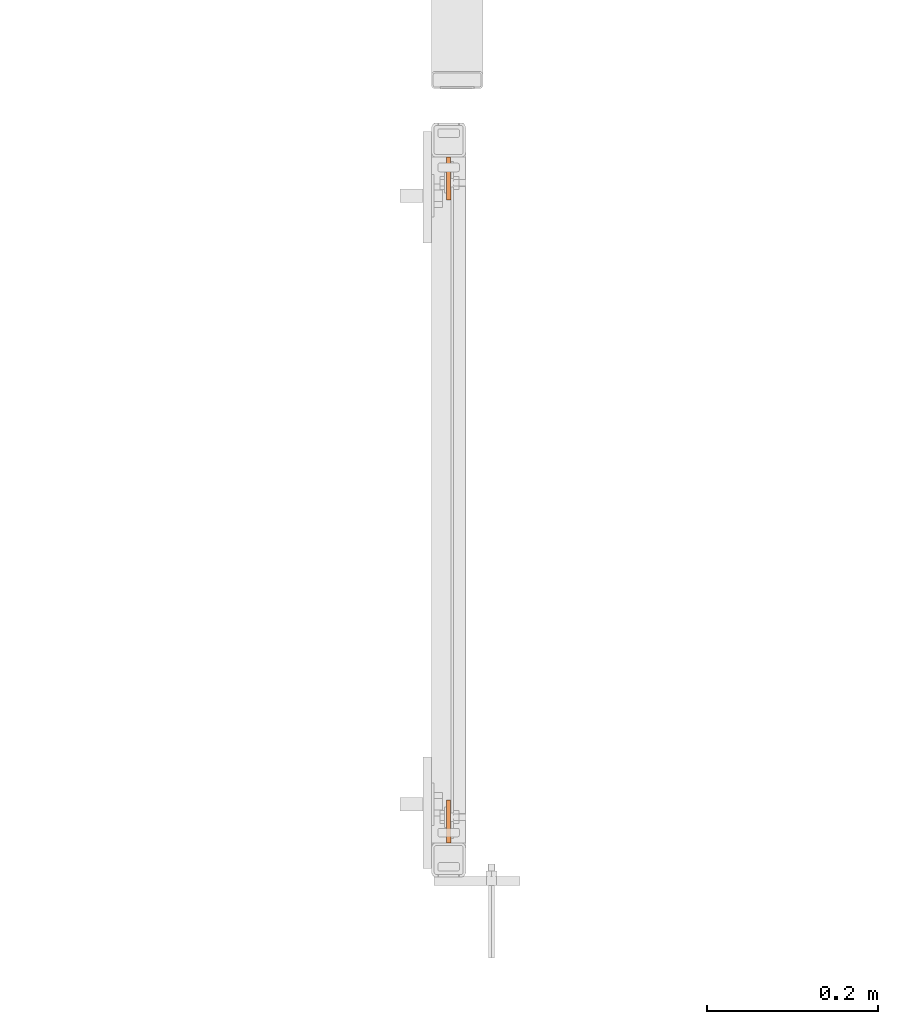
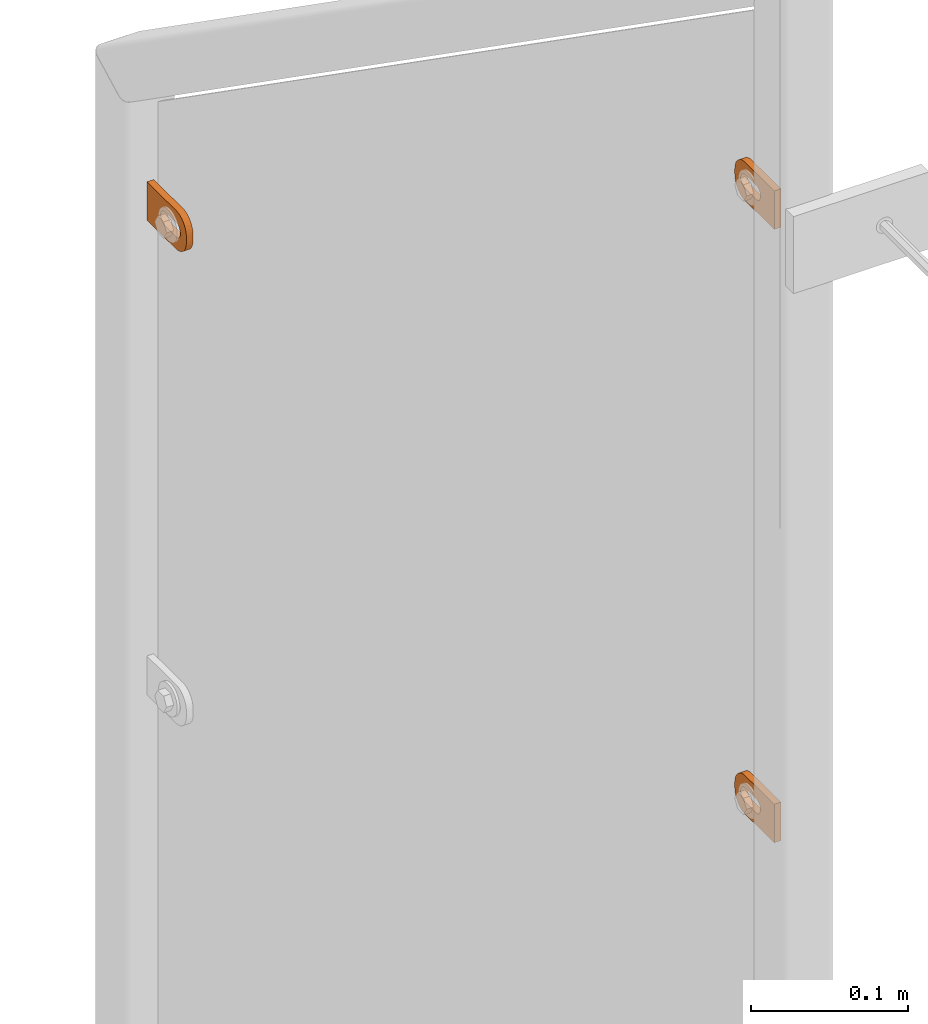
# One storey, part 139 of 156: 3 proxies, 1 element without a shape of its own.
"""IFC2X3 building model written with IfcOpenShell, lengths in millimetres."""

from ifc_helpers import new_model, si_unit, frame, origin_with_axes, place, context, subcontext, project, spatial, faceted_brep, material, type_object, element, aggregate, save


model = new_model("IFC2X3")

# Units and contexts
model_context = context("Model", 3, precision=1e-05, world=origin_with_axes())
body_context = subcontext(model_context, "Body", "Model", "MODEL_VIEW")
ifc_project = project(units=[si_unit("LENGTHUNIT", "METRE", prefix="MILLI"), si_unit("AREAUNIT", "SQUARE_METRE"), si_unit("VOLUMEUNIT", "CUBIC_METRE"), si_unit("MASSUNIT", "GRAM", prefix="KILO"), si_unit("TIMEUNIT", "SECOND"), si_unit("PLANEANGLEUNIT", "RADIAN"), si_unit("SOLIDANGLEUNIT", "STERADIAN"), si_unit("THERMODYNAMICTEMPERATUREUNIT", "DEGREE_CELSIUS"), si_unit("LUMINOUSINTENSITYUNIT", "LUMEN")], contexts=[model_context])

# Site, building, storey
site_placement = place(None, origin_with_axes())
site = spatial("IfcSite", under=ifc_project, at=site_placement, CompositionType="ELEMENT")
building_placement = place(site_placement, origin_with_axes())
building = spatial("IfcBuilding", under=site, at=building_placement, Name="Undefined", CompositionType="ELEMENT")
storey_placement = place(building_placement, origin_with_axes())
storey = spatial("IfcBuildingStorey", under=building, at=storey_placement, Name="Undefined", CompositionType="ELEMENT", Elevation=0.0)

# Assembly, proxies
assembly_placement = place(storey_placement, origin_with_axes())
assembly = element("IfcElementAssembly", 1, at=assembly_placement, inside=storey, AssemblyPlace="NOTDEFINED", PredefinedType="RIGID_FRAME")
ifc_material = material(Name="STEEL/S235JR")
building_element_proxy_type = type_object("IfcBuildingElementProxyType", Name="50", PredefinedType="NOTDEFINED")
proxy_1_placement = place(assembly_placement, frame((26914.9961242676, 22558.0099050151, 5289.31155036594), z_axis=(0.999985556002151, 0.00537473600001249, 0.0), x_axis=(-0.00537473600001187, 0.999985556002151, 1.19999999540802e-08)))
proxy_1 = element("IfcBuildingElementProxy", 2, at=proxy_1_placement, type_object=building_element_proxy_type, material=ifc_material, ObjectType="50", CompositionType="ELEMENT", context=body_context, shape_type="Brep", body=[
    faceted_brep([(37.0000004768226, -5.50000056624776, -2.49999994410609), (23.0000000446889, -5.50000056624594, -2.49999994410973), (23.0000000446889, -5.50000056624594, 2.49999994413156), (37.000000476819, -5.50000056624776, 2.49999994413338), (21.9270028173814, -5.39431966841403, -2.49999994410973), (21.9270028173778, -5.39431966841403, 2.49999994412792), (20.895240828384, -5.0813375413436, -2.49999994411155), (20.895240828384, -5.0813375413436, 2.49999994412974), (19.9443642049955, -4.5730831474084, -2.49999994410973), (19.9443642049919, -4.5730831474084, 2.49999994412792), (19.1109124571012, -3.88908818364325, -2.49999994411155), (19.1109124571012, -3.88908818364325, 2.49999994412792), (18.4269174933361, -3.05563643574806, -2.49999994411155), (18.4269174933361, -3.05563643574806, 2.4999999441261), (17.9186630994009, -2.1047579497108, -2.49999994411155), (17.9186630994009, -2.1047579497108, 2.49999994412428), (17.6056809723377, -1.07299596071425, -2.49999994411337), (17.6056809723341, -1.07299596071425, 2.4999999441261), (17.5000000745022, 3.3527521736687e-07, -2.49999994411519), (17.5000000745058, 3.3527521736687e-07, 2.49999994412428), (17.6056809723377, 1.07299663126287, -2.49999994411701), (17.6056809723377, 1.07299663126287, 2.49999994412428), (17.9186630994154, 2.10475862026124, -2.49999994411701), (17.9186630994118, 2.10475862026124, 2.49999994412246), (18.426917493347, 3.05563617497592, -2.49999994411701), (18.426917493347, 3.05563617497592, 2.49999994412246), (19.1109124571158, 3.88908699154672, -2.49999994411883), (19.1109124571121, 3.88908699154672, 2.49999994412065), (19.9443642050101, 4.57308288663444, -2.49999994411701), (19.9443642050064, 4.57308288663444, 2.49999994412065), (20.8952408283985, 5.08133728056964, -2.49999994411883), (20.8952408283985, 5.08133728056964, 2.49999994412065), (21.9270028173996, 5.39431940764007, -2.49999994411883), (21.927002817396, 5.39431940764007, 2.49999994412065), (23.0000000447108, 5.50000030547199, -2.49999994411883), (23.0000000447071, 5.50000030547199, 2.49999994412246), (37.0000004768408, 5.50000030547017, -2.49999994411519), (37.0000004768408, 5.50000030547017, 2.49999994412428), (38.0729958415031, 5.39431940763825, -2.49999994411519), (38.0729958414995, 5.39431940763825, 2.49999994412428), (39.1047596931458, 5.08133728056691, -2.49999994411337), (39.1047596931421, 5.08133728056691, 2.49999994412428), (40.0556363165415, 4.57308288663171, -2.49999994411519), (40.0556363165379, 4.57308288663171, 2.4999999441261), (40.8890880644285, 3.8890869915449, -2.49999994411337), (40.8890880644285, 3.8890869915449, 2.49999994412792), (41.5730811655449, 3.05563617497228, -2.49999994411337), (41.5730811655449, 3.05563617497228, 2.4999999441261), (42.0813374221252, 2.1047586202576, -2.49999994411155), (42.0813374221252, 2.1047586202576, 2.49999994412792), (42.3943176865469, 1.07299663126014, -2.49999994410973), (42.3943176865469, 1.07299663126014, 2.49999994412974), (42.5000004470239, 3.35271579388063e-07, -2.49999994410973), (42.5000004470276, 3.35271579388063e-07, 2.49999994412974), (42.3943176865469, -1.07299596071698, -2.49999994410791), (42.3943176865432, -1.07299596071698, 2.49999994413156), (42.0813374221179, -2.10475794971444, -2.49999994410791), (42.0813374221143, -2.10475794971444, 2.49999994413338), (41.5730811655376, -3.05563643575169, -2.49999994410791), (41.5730811655339, -3.05563643575169, 2.49999994413156), (40.8890880644176, -3.88908818364507, -2.49999994410609), (40.889088064414, -3.88908818364507, 2.49999994413338), (40.0556363165233, -4.57308314741113, -2.49999994410791), (40.0556363165233, -4.57308314741113, 2.49999994413338), (39.1047596931276, -5.08133754134633, -2.49999994410609), (39.1047596931276, -5.08133754134633, 2.49999994413338), (38.072995841485, -5.39431966841585, -2.49999994410609), (38.072995841485, -5.39431966841585, 2.49999994413156), (37.0000004768044, -14.9999993294514, 2.49999994414065), (39.5361743867034, -14.7502093017147, 2.49999994414065), (41.9748835265273, -14.0104337036646, 2.49999994414065), (44.222414493528, -12.8091058135078, 2.49999994414247), (46.192388981548, -11.1923875659759, 2.49999994413884), (47.809105366443, -9.22241307795593, 2.49999994413884), (49.010433256597, -6.97488397360394, 2.49999994413702), (49.7502088546535, -4.53617483378002, 2.49999994413338), (50.0000007450435, -2.00000092387745, 2.49999994413338), (50.0000007450471, 1.99999973177364, 2.49999994412974), (49.7502088546717, 4.53617457299879, 2.4999999441261), (49.0104332566261, 6.97488464414528, 2.4999999441261), (47.8091053664721, 9.2224128171747, 2.49999994412428), (46.192388981588, 11.1923882365172, 2.49999994412065), (44.2224144935717, 12.8091048542365, 2.49999994411883), (41.9748835265782, 14.0104339085483, 2.49999994411883), (39.5361743867543, 14.7502086334816, 2.49999994411701), (37.0000004768553, 14.9999999999964, 2.49999994411519), (2.91038304567337e-11, 15.0000000000009, 2.49999994410791), (-2.18278728425503e-11, -14.9999993294468, 2.49999994413338), (3.27418092638254e-11, 15.0000000000009, -2.49999994413156), (-2.18278728425503e-11, -14.9999993294468, -2.49999994410791), (37.0000004768008, -14.9999993294514, -2.49999994409882), (39.5361743867034, -14.7502093017147, -2.49999994409882), (41.9748835265309, -14.0104337036646, -2.499999944097), (44.222414493528, -12.8091058135078, -2.49999994409882), (46.1923889815516, -11.1923875659759, -2.49999994409882), (47.8091053664393, -9.22241307795593, -2.49999994410064), (49.0104332566007, -6.97488397360394, -2.49999994410246), (49.7502088546535, -4.53617483378002, -2.49999994410609), (50.0000007450435, -2.00000092387745, -2.49999994410609), (50.0000007450508, 1.99999973177364, -2.49999994410973), (49.750208854668, 4.53617457299879, -2.49999994411155), (49.0104332566261, 6.97488464414528, -2.49999994411337), (47.8091053664721, 9.2224128171747, -2.49999994411519), (46.1923889815916, 11.1923882365172, -2.49999994411883), (44.2224144935717, 12.8091048542365, -2.49999994411883), (41.9748835265782, 14.0104339085483, -2.49999994412065), (39.5361743867579, 14.7502086334816, -2.49999994412246), (37.000000476859, 14.9999999999964, -2.49999994412428)], [[[0, 1, 2, 3]], [[1, 4, 5, 2]], [[4, 6, 7, 5]], [[6, 8, 9, 7]], [[8, 10, 11, 9]], [[10, 12, 13, 11]], [[12, 14, 15, 13]], [[14, 16, 17, 15]], [[16, 18, 19, 17]], [[18, 20, 21, 19]], [[20, 22, 23, 21]], [[22, 24, 25, 23]], [[24, 26, 27, 25]], [[26, 28, 29, 27]], [[28, 30, 31, 29]], [[30, 32, 33, 31]], [[32, 34, 35, 33]], [[34, 36, 37, 35]], [[36, 38, 39, 37]], [[38, 40, 41, 39]], [[40, 42, 43, 41]], [[42, 44, 45, 43]], [[44, 46, 47, 45]], [[46, 48, 49, 47]], [[48, 50, 51, 49]], [[50, 52, 53, 51]], [[52, 54, 55, 53]], [[54, 56, 57, 55]], [[56, 58, 59, 57]], [[58, 60, 61, 59]], [[60, 62, 63, 61]], [[62, 64, 65, 63]], [[64, 66, 67, 65]], [[66, 0, 3, 67]], [[68, 69, 70, 71, 72, 73, 74, 75, 76, 77, 78, 79, 80, 81, 82, 83, 84, 85, 86, 87], [5, 7, 9, 11, 13, 15, 17, 19, 21, 23, 25, 27, 29, 31, 33, 35, 37, 39, 41, 43, 45, 47, 49, 51, 53, 55, 57, 59, 61, 63, 65, 67, 3, 2]], [[86, 88, 89, 87]], [[87, 89, 90, 68]], [[68, 90, 91, 69]], [[69, 91, 92, 70]], [[70, 92, 93, 71]], [[71, 93, 94, 72]], [[72, 94, 95, 73]], [[73, 95, 96, 74]], [[74, 96, 97, 75]], [[75, 97, 98, 76]], [[76, 98, 99, 77]], [[77, 99, 100, 78]], [[78, 100, 101, 79]], [[79, 101, 102, 80]], [[80, 102, 103, 81]], [[81, 103, 104, 82]], [[82, 104, 105, 83]], [[83, 105, 106, 84]], [[84, 106, 107, 85]], [[85, 107, 88, 86]], [[105, 104, 103, 102, 101, 100, 99, 98, 97, 96, 95, 94, 93, 92, 91, 90, 89, 88, 107, 106], [60, 58, 56, 54, 52, 50, 48, 46, 44, 42, 40, 38, 36, 34, 32, 30, 28, 26, 24, 22, 20, 18, 16, 14, 12, 10, 8, 6, 4, 1, 0, 66, 64, 62]]]),
])
proxy_2_placement = place(assembly_placement, frame((26914.7461242676, 23358.0462491401, 4811.41994708695), z_axis=(-0.999985556002151, -0.00537473600001249, 0.0), x_axis=(0.00537473600001187, -0.999985556002151, 1.19999999540802e-08)))
proxy_2 = element("IfcBuildingElementProxy", 3, at=proxy_2_placement, type_object=building_element_proxy_type, material=ifc_material, ObjectType="50", CompositionType="ELEMENT", context=body_context, shape_type="Brep", body=[
    faceted_brep([(37.0000004768226, -5.50000056624776, -2.49999994410609), (23.0000000446889, -5.50000056624594, -2.49999994410973), (23.0000000446889, -5.50000056624594, 2.49999994413156), (37.000000476819, -5.50000056624776, 2.49999994413338), (21.9270028173814, -5.39431966841403, -2.49999994410973), (21.9270028173778, -5.39431966841403, 2.49999994412792), (20.895240828384, -5.0813375413436, -2.49999994411155), (20.895240828384, -5.0813375413436, 2.49999994412974), (19.9443642049955, -4.5730831474084, -2.49999994410973), (19.9443642049919, -4.5730831474084, 2.49999994412792), (19.1109124571012, -3.88908818364325, -2.49999994411155), (19.1109124571012, -3.88908818364325, 2.49999994412792), (18.4269174933361, -3.05563643574806, -2.49999994411155), (18.4269174933361, -3.05563643574806, 2.4999999441261), (17.9186630994009, -2.1047579497108, -2.49999994411155), (17.9186630994009, -2.1047579497108, 2.49999994412428), (17.6056809723377, -1.07299596071425, -2.49999994411337), (17.6056809723341, -1.07299596071425, 2.4999999441261), (17.5000000745022, 3.3527521736687e-07, -2.49999994411519), (17.5000000745058, 3.3527521736687e-07, 2.49999994412428), (17.6056809723377, 1.07299663126287, -2.49999994411701), (17.6056809723377, 1.07299663126287, 2.49999994412428), (17.9186630994154, 2.10475862026124, -2.49999994411701), (17.9186630994118, 2.10475862026124, 2.49999994412246), (18.426917493347, 3.05563617497592, -2.49999994411701), (18.426917493347, 3.05563617497592, 2.49999994412246), (19.1109124571158, 3.88908699154672, -2.49999994411883), (19.1109124571121, 3.88908699154672, 2.49999994412065), (19.9443642050101, 4.57308288663444, -2.49999994411701), (19.9443642050064, 4.57308288663444, 2.49999994412065), (20.8952408283985, 5.08133728056964, -2.49999994411883), (20.8952408283985, 5.08133728056964, 2.49999994412065), (21.9270028173996, 5.39431940764007, -2.49999994411883), (21.927002817396, 5.39431940764007, 2.49999994412065), (23.0000000447108, 5.50000030547199, -2.49999994411883), (23.0000000447071, 5.50000030547199, 2.49999994412246), (37.0000004768408, 5.50000030547017, -2.49999994411519), (37.0000004768408, 5.50000030547017, 2.49999994412428), (38.0729958415031, 5.39431940763825, -2.49999994411519), (38.0729958414995, 5.39431940763825, 2.49999994412428), (39.1047596931458, 5.08133728056691, -2.49999994411337), (39.1047596931421, 5.08133728056691, 2.49999994412428), (40.0556363165415, 4.57308288663171, -2.49999994411519), (40.0556363165379, 4.57308288663171, 2.4999999441261), (40.8890880644285, 3.8890869915449, -2.49999994411337), (40.8890880644285, 3.8890869915449, 2.49999994412792), (41.5730811655449, 3.05563617497228, -2.49999994411337), (41.5730811655449, 3.05563617497228, 2.4999999441261), (42.0813374221252, 2.1047586202576, -2.49999994411155), (42.0813374221252, 2.1047586202576, 2.49999994412792), (42.3943176865469, 1.07299663126014, -2.49999994410973), (42.3943176865469, 1.07299663126014, 2.49999994412974), (42.5000004470239, 3.35271579388063e-07, -2.49999994410973), (42.5000004470276, 3.35271579388063e-07, 2.49999994412974), (42.3943176865469, -1.07299596071698, -2.49999994410791), (42.3943176865432, -1.07299596071698, 2.49999994413156), (42.0813374221179, -2.10475794971444, -2.49999994410791), (42.0813374221143, -2.10475794971444, 2.49999994413338), (41.5730811655376, -3.05563643575169, -2.49999994410791), (41.5730811655339, -3.05563643575169, 2.49999994413156), (40.8890880644176, -3.88908818364507, -2.49999994410609), (40.889088064414, -3.88908818364507, 2.49999994413338), (40.0556363165233, -4.57308314741113, -2.49999994410791), (40.0556363165233, -4.57308314741113, 2.49999994413338), (39.1047596931276, -5.08133754134633, -2.49999994410609), (39.1047596931276, -5.08133754134633, 2.49999994413338), (38.072995841485, -5.39431966841585, -2.49999994410609), (38.072995841485, -5.39431966841585, 2.49999994413156), (37.0000004768044, -14.9999993294514, 2.49999994414065), (39.5361743867034, -14.7502093017147, 2.49999994414065), (41.9748835265273, -14.0104337036646, 2.49999994414065), (44.222414493528, -12.8091058135078, 2.49999994414247), (46.192388981548, -11.1923875659759, 2.49999994413884), (47.809105366443, -9.22241307795593, 2.49999994413884), (49.010433256597, -6.97488397360394, 2.49999994413702), (49.7502088546535, -4.53617483378002, 2.49999994413338), (50.0000007450435, -2.00000092387745, 2.49999994413338), (50.0000007450471, 1.99999973177364, 2.49999994412974), (49.7502088546717, 4.53617457299879, 2.4999999441261), (49.0104332566261, 6.97488464414528, 2.4999999441261), (47.8091053664721, 9.2224128171747, 2.49999994412428), (46.192388981588, 11.1923882365172, 2.49999994412065), (44.2224144935717, 12.8091048542365, 2.49999994411883), (41.9748835265782, 14.0104339085483, 2.49999994411883), (39.5361743867543, 14.7502086334816, 2.49999994411701), (37.0000004768553, 14.9999999999964, 2.49999994411519), (2.91038304567337e-11, 15.0000000000009, 2.49999994410791), (-2.18278728425503e-11, -14.9999993294468, 2.49999994413338), (3.27418092638254e-11, 15.0000000000009, -2.49999994413156), (-2.18278728425503e-11, -14.9999993294468, -2.49999994410791), (37.0000004768008, -14.9999993294514, -2.49999994409882), (39.5361743867034, -14.7502093017147, -2.49999994409882), (41.9748835265309, -14.0104337036646, -2.499999944097), (44.222414493528, -12.8091058135078, -2.49999994409882), (46.1923889815516, -11.1923875659759, -2.49999994409882), (47.8091053664393, -9.22241307795593, -2.49999994410064), (49.0104332566007, -6.97488397360394, -2.49999994410246), (49.7502088546535, -4.53617483378002, -2.49999994410609), (50.0000007450435, -2.00000092387745, -2.49999994410609), (50.0000007450508, 1.99999973177364, -2.49999994410973), (49.750208854668, 4.53617457299879, -2.49999994411155), (49.0104332566261, 6.97488464414528, -2.49999994411337), (47.8091053664721, 9.2224128171747, -2.49999994411519), (46.1923889815916, 11.1923882365172, -2.49999994411883), (44.2224144935717, 12.8091048542365, -2.49999994411883), (41.9748835265782, 14.0104339085483, -2.49999994412065), (39.5361743867579, 14.7502086334816, -2.49999994412246), (37.000000476859, 14.9999999999964, -2.49999994412428)], [[[0, 1, 2, 3]], [[1, 4, 5, 2]], [[4, 6, 7, 5]], [[6, 8, 9, 7]], [[8, 10, 11, 9]], [[10, 12, 13, 11]], [[12, 14, 15, 13]], [[14, 16, 17, 15]], [[16, 18, 19, 17]], [[18, 20, 21, 19]], [[20, 22, 23, 21]], [[22, 24, 25, 23]], [[24, 26, 27, 25]], [[26, 28, 29, 27]], [[28, 30, 31, 29]], [[30, 32, 33, 31]], [[32, 34, 35, 33]], [[34, 36, 37, 35]], [[36, 38, 39, 37]], [[38, 40, 41, 39]], [[40, 42, 43, 41]], [[42, 44, 45, 43]], [[44, 46, 47, 45]], [[46, 48, 49, 47]], [[48, 50, 51, 49]], [[50, 52, 53, 51]], [[52, 54, 55, 53]], [[54, 56, 57, 55]], [[56, 58, 59, 57]], [[58, 60, 61, 59]], [[60, 62, 63, 61]], [[62, 64, 65, 63]], [[64, 66, 67, 65]], [[66, 0, 3, 67]], [[68, 69, 70, 71, 72, 73, 74, 75, 76, 77, 78, 79, 80, 81, 82, 83, 84, 85, 86, 87], [5, 7, 9, 11, 13, 15, 17, 19, 21, 23, 25, 27, 29, 31, 33, 35, 37, 39, 41, 43, 45, 47, 49, 51, 53, 55, 57, 59, 61, 63, 65, 67, 3, 2]], [[86, 88, 89, 87]], [[87, 89, 90, 68]], [[68, 90, 91, 69]], [[69, 91, 92, 70]], [[70, 92, 93, 71]], [[71, 93, 94, 72]], [[72, 94, 95, 73]], [[73, 95, 96, 74]], [[74, 96, 97, 75]], [[75, 97, 98, 76]], [[76, 98, 99, 77]], [[77, 99, 100, 78]], [[78, 100, 101, 79]], [[79, 101, 102, 80]], [[80, 102, 103, 81]], [[81, 103, 104, 82]], [[82, 104, 105, 83]], [[83, 105, 106, 84]], [[84, 106, 107, 85]], [[85, 107, 88, 86]], [[105, 104, 103, 102, 101, 100, 99, 98, 97, 96, 95, 94, 93, 92, 91, 90, 89, 88, 107, 106], [60, 58, 56, 54, 52, 50, 48, 46, 44, 42, 40, 38, 36, 34, 32, 30, 28, 26, 24, 22, 20, 18, 16, 14, 12, 10, 8, 6, 4, 1, 0, 66, 64, 62]]]),
])
proxy_3_placement = place(assembly_placement, frame((26914.9961242676, 22558.0453699462, 4811.62928193643), z_axis=(0.999985556002151, 0.00537473600001249, 0.0), x_axis=(-0.00537473600001187, 0.999985556002151, 1.19999999540802e-08)))
proxy_3 = element("IfcBuildingElementProxy", 4, at=proxy_3_placement, type_object=building_element_proxy_type, material=ifc_material, ObjectType="50", CompositionType="ELEMENT", context=body_context, shape_type="Brep", body=[
    faceted_brep([(37.0000004768226, -5.50000056624776, -2.49999994410609), (23.0000000446889, -5.50000056624594, -2.49999994410973), (23.0000000446889, -5.50000056624594, 2.49999994413156), (37.000000476819, -5.50000056624776, 2.49999994413338), (21.9270028173814, -5.39431966841403, -2.49999994410973), (21.9270028173778, -5.39431966841403, 2.49999994412792), (20.895240828384, -5.0813375413436, -2.49999994411155), (20.895240828384, -5.0813375413436, 2.49999994412974), (19.9443642049955, -4.5730831474084, -2.49999994410973), (19.9443642049919, -4.5730831474084, 2.49999994412792), (19.1109124571012, -3.88908818364325, -2.49999994411155), (19.1109124571012, -3.88908818364325, 2.49999994412792), (18.4269174933361, -3.05563643574806, -2.49999994411155), (18.4269174933361, -3.05563643574806, 2.4999999441261), (17.9186630994009, -2.1047579497108, -2.49999994411155), (17.9186630994009, -2.1047579497108, 2.49999994412428), (17.6056809723377, -1.07299596071425, -2.49999994411337), (17.6056809723341, -1.07299596071425, 2.4999999441261), (17.5000000745022, 3.3527521736687e-07, -2.49999994411519), (17.5000000745058, 3.3527521736687e-07, 2.49999994412428), (17.6056809723377, 1.07299663126287, -2.49999994411701), (17.6056809723377, 1.07299663126287, 2.49999994412428), (17.9186630994154, 2.10475862026124, -2.49999994411701), (17.9186630994118, 2.10475862026124, 2.49999994412246), (18.426917493347, 3.05563617497592, -2.49999994411701), (18.426917493347, 3.05563617497592, 2.49999994412246), (19.1109124571158, 3.88908699154672, -2.49999994411883), (19.1109124571121, 3.88908699154672, 2.49999994412065), (19.9443642050101, 4.57308288663444, -2.49999994411701), (19.9443642050064, 4.57308288663444, 2.49999994412065), (20.8952408283985, 5.08133728056964, -2.49999994411883), (20.8952408283985, 5.08133728056964, 2.49999994412065), (21.9270028173996, 5.39431940764007, -2.49999994411883), (21.927002817396, 5.39431940764007, 2.49999994412065), (23.0000000447108, 5.50000030547199, -2.49999994411883), (23.0000000447071, 5.50000030547199, 2.49999994412246), (37.0000004768408, 5.50000030547017, -2.49999994411519), (37.0000004768408, 5.50000030547017, 2.49999994412428), (38.0729958415031, 5.39431940763825, -2.49999994411519), (38.0729958414995, 5.39431940763825, 2.49999994412428), (39.1047596931458, 5.08133728056691, -2.49999994411337), (39.1047596931421, 5.08133728056691, 2.49999994412428), (40.0556363165415, 4.57308288663171, -2.49999994411519), (40.0556363165379, 4.57308288663171, 2.4999999441261), (40.8890880644285, 3.8890869915449, -2.49999994411337), (40.8890880644285, 3.8890869915449, 2.49999994412792), (41.5730811655449, 3.05563617497228, -2.49999994411337), (41.5730811655449, 3.05563617497228, 2.4999999441261), (42.0813374221252, 2.1047586202576, -2.49999994411155), (42.0813374221252, 2.1047586202576, 2.49999994412792), (42.3943176865469, 1.07299663126014, -2.49999994410973), (42.3943176865469, 1.07299663126014, 2.49999994412974), (42.5000004470239, 3.35271579388063e-07, -2.49999994410973), (42.5000004470276, 3.35271579388063e-07, 2.49999994412974), (42.3943176865469, -1.07299596071698, -2.49999994410791), (42.3943176865432, -1.07299596071698, 2.49999994413156), (42.0813374221179, -2.10475794971444, -2.49999994410791), (42.0813374221143, -2.10475794971444, 2.49999994413338), (41.5730811655376, -3.05563643575169, -2.49999994410791), (41.5730811655339, -3.05563643575169, 2.49999994413156), (40.8890880644176, -3.88908818364507, -2.49999994410609), (40.889088064414, -3.88908818364507, 2.49999994413338), (40.0556363165233, -4.57308314741113, -2.49999994410791), (40.0556363165233, -4.57308314741113, 2.49999994413338), (39.1047596931276, -5.08133754134633, -2.49999994410609), (39.1047596931276, -5.08133754134633, 2.49999994413338), (38.072995841485, -5.39431966841585, -2.49999994410609), (38.072995841485, -5.39431966841585, 2.49999994413156), (37.0000004768044, -14.9999993294514, 2.49999994414065), (39.5361743867034, -14.7502093017147, 2.49999994414065), (41.9748835265273, -14.0104337036646, 2.49999994414065), (44.222414493528, -12.8091058135078, 2.49999994414247), (46.192388981548, -11.1923875659759, 2.49999994413884), (47.809105366443, -9.22241307795593, 2.49999994413884), (49.010433256597, -6.97488397360394, 2.49999994413702), (49.7502088546535, -4.53617483378002, 2.49999994413338), (50.0000007450435, -2.00000092387745, 2.49999994413338), (50.0000007450471, 1.99999973177364, 2.49999994412974), (49.7502088546717, 4.53617457299879, 2.4999999441261), (49.0104332566261, 6.97488464414528, 2.4999999441261), (47.8091053664721, 9.2224128171747, 2.49999994412428), (46.192388981588, 11.1923882365172, 2.49999994412065), (44.2224144935717, 12.8091048542365, 2.49999994411883), (41.9748835265782, 14.0104339085483, 2.49999994411883), (39.5361743867543, 14.7502086334816, 2.49999994411701), (37.0000004768553, 14.9999999999964, 2.49999994411519), (2.91038304567337e-11, 15.0000000000009, 2.49999994410791), (-2.18278728425503e-11, -14.9999993294468, 2.49999994413338), (3.27418092638254e-11, 15.0000000000009, -2.49999994413156), (-2.18278728425503e-11, -14.9999993294468, -2.49999994410791), (37.0000004768008, -14.9999993294514, -2.49999994409882), (39.5361743867034, -14.7502093017147, -2.49999994409882), (41.9748835265309, -14.0104337036646, -2.499999944097), (44.222414493528, -12.8091058135078, -2.49999994409882), (46.1923889815516, -11.1923875659759, -2.49999994409882), (47.8091053664393, -9.22241307795593, -2.49999994410064), (49.0104332566007, -6.97488397360394, -2.49999994410246), (49.7502088546535, -4.53617483378002, -2.49999994410609), (50.0000007450435, -2.00000092387745, -2.49999994410609), (50.0000007450508, 1.99999973177364, -2.49999994410973), (49.750208854668, 4.53617457299879, -2.49999994411155), (49.0104332566261, 6.97488464414528, -2.49999994411337), (47.8091053664721, 9.2224128171747, -2.49999994411519), (46.1923889815916, 11.1923882365172, -2.49999994411883), (44.2224144935717, 12.8091048542365, -2.49999994411883), (41.9748835265782, 14.0104339085483, -2.49999994412065), (39.5361743867579, 14.7502086334816, -2.49999994412246), (37.000000476859, 14.9999999999964, -2.49999994412428)], [[[0, 1, 2, 3]], [[1, 4, 5, 2]], [[4, 6, 7, 5]], [[6, 8, 9, 7]], [[8, 10, 11, 9]], [[10, 12, 13, 11]], [[12, 14, 15, 13]], [[14, 16, 17, 15]], [[16, 18, 19, 17]], [[18, 20, 21, 19]], [[20, 22, 23, 21]], [[22, 24, 25, 23]], [[24, 26, 27, 25]], [[26, 28, 29, 27]], [[28, 30, 31, 29]], [[30, 32, 33, 31]], [[32, 34, 35, 33]], [[34, 36, 37, 35]], [[36, 38, 39, 37]], [[38, 40, 41, 39]], [[40, 42, 43, 41]], [[42, 44, 45, 43]], [[44, 46, 47, 45]], [[46, 48, 49, 47]], [[48, 50, 51, 49]], [[50, 52, 53, 51]], [[52, 54, 55, 53]], [[54, 56, 57, 55]], [[56, 58, 59, 57]], [[58, 60, 61, 59]], [[60, 62, 63, 61]], [[62, 64, 65, 63]], [[64, 66, 67, 65]], [[66, 0, 3, 67]], [[68, 69, 70, 71, 72, 73, 74, 75, 76, 77, 78, 79, 80, 81, 82, 83, 84, 85, 86, 87], [5, 7, 9, 11, 13, 15, 17, 19, 21, 23, 25, 27, 29, 31, 33, 35, 37, 39, 41, 43, 45, 47, 49, 51, 53, 55, 57, 59, 61, 63, 65, 67, 3, 2]], [[86, 88, 89, 87]], [[87, 89, 90, 68]], [[68, 90, 91, 69]], [[69, 91, 92, 70]], [[70, 92, 93, 71]], [[71, 93, 94, 72]], [[72, 94, 95, 73]], [[73, 95, 96, 74]], [[74, 96, 97, 75]], [[75, 97, 98, 76]], [[76, 98, 99, 77]], [[77, 99, 100, 78]], [[78, 100, 101, 79]], [[79, 101, 102, 80]], [[80, 102, 103, 81]], [[81, 103, 104, 82]], [[82, 104, 105, 83]], [[83, 105, 106, 84]], [[84, 106, 107, 85]], [[85, 107, 88, 86]], [[105, 104, 103, 102, 101, 100, 99, 98, 97, 96, 95, 94, 93, 92, 91, 90, 89, 88, 107, 106], [60, 58, 56, 54, 52, 50, 48, 46, 44, 42, 40, 38, 36, 34, 32, 30, 28, 26, 24, 22, 20, 18, 16, 14, 12, 10, 8, 6, 4, 1, 0, 66, 64, 62]]]),
])
aggregate(assembly, [proxy_1, proxy_2, proxy_3])

save(model, "model.ifc")
